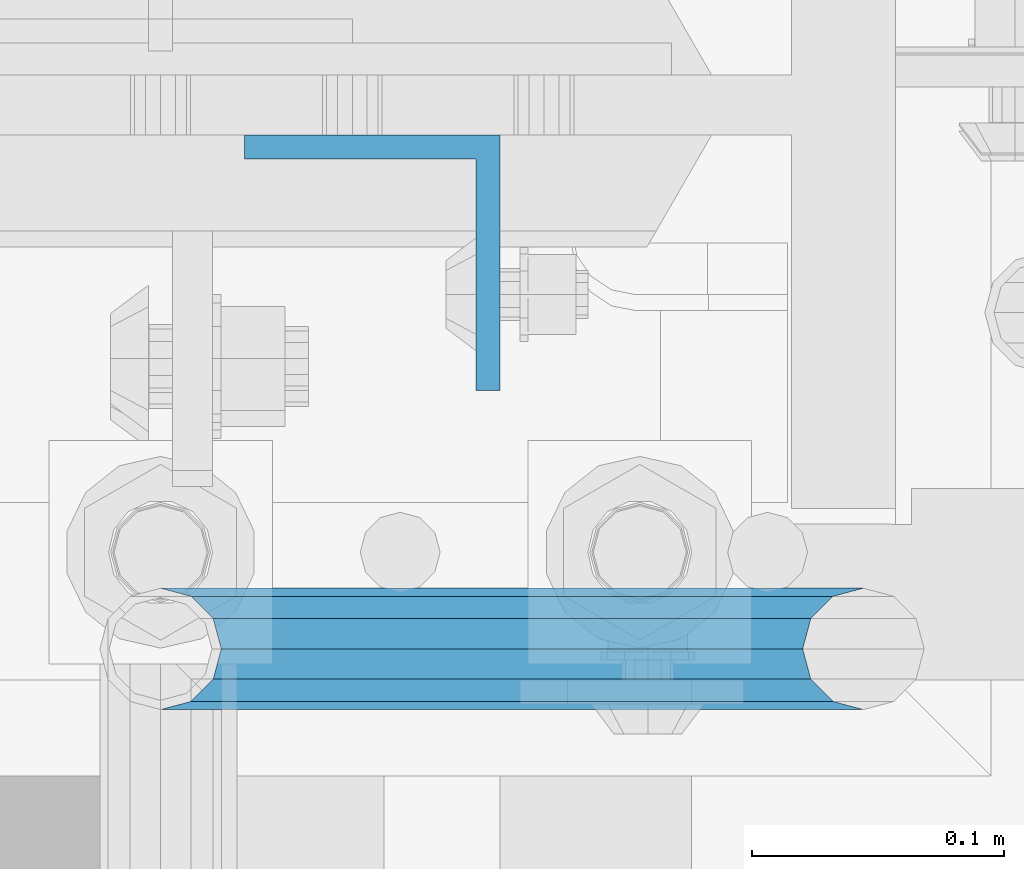
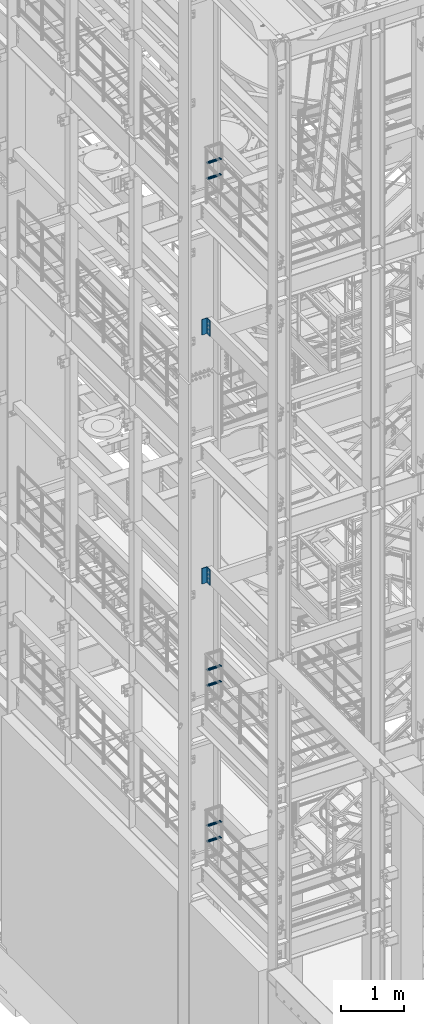
# One storey, part 1159 of 1876: 8 beams, 5 elements without a shape of their own.
"""IFC2X3 building model written with IfcOpenShell, lengths in millimetres."""

from ifc_helpers import new_model, si_unit, frame, origin_with_axes, place, context, subcontext, project, spatial, faceted_brep, material, type_object, element, aggregate, save


model = new_model("IFC2X3")

# Units and contexts
model_context = context("Model", 3, precision=1e-05, world=origin_with_axes())
body_context = subcontext(model_context, "Body", "Model", "MODEL_VIEW")
ifc_project = project(units=[si_unit("LENGTHUNIT", "METRE", prefix="MILLI"), si_unit("AREAUNIT", "SQUARE_METRE"), si_unit("VOLUMEUNIT", "CUBIC_METRE"), si_unit("MASSUNIT", "GRAM", prefix="KILO"), si_unit("TIMEUNIT", "SECOND"), si_unit("PLANEANGLEUNIT", "RADIAN"), si_unit("SOLIDANGLEUNIT", "STERADIAN"), si_unit("THERMODYNAMICTEMPERATUREUNIT", "DEGREE_CELSIUS"), si_unit("LUMINOUSINTENSITYUNIT", "LUMEN")], contexts=[model_context])

# Site, building, storey
site_placement = place(None, origin_with_axes())
site = spatial("IfcSite", under=ifc_project, at=site_placement, CompositionType="ELEMENT")
building_placement = place(site_placement, origin_with_axes())
building = spatial("IfcBuilding", under=site, at=building_placement, Name="Undefined", CompositionType="ELEMENT")
storey_placement = place(building_placement, origin_with_axes())
storey = spatial("IfcBuildingStorey", under=building, at=storey_placement, Name="Undefined", CompositionType="ELEMENT", Elevation=0.0)

# Assembly, beams
assembly_1_placement = place(storey_placement, origin_with_axes())
assembly_1 = element("IfcElementAssembly", 1, at=assembly_1_placement, inside=storey, Name="RAIL", AssemblyPlace="NOTDEFINED", PredefinedType="RIGID_FRAME")
ifc_material_1 = material()
beam_type_1 = type_object("IfcBeamType", Name="PIPE1-1/2SCH40", PredefinedType="NOTDEFINED")
beam_1_placement = place(assembly_1_placement, frame((0.0, -4788.2175, 18449.925000036), z_axis=(0.0, 0.0, 1.0), x_axis=(1.0, 0.0, 0.0)))
beam_1 = element("IfcBeam", 2, at=beam_1_placement, type_object=beam_type_1, material=ifc_material_1, Name="RAIL", ObjectType="PIPE1-1/2SCH40", context=body_context, shape_type="Brep", body=[
    faceted_brep([(258.502800903171, -12.0650000000005, 20.8971929933177), (258.502800903171, -12.0650000000005, 15.8661214311796), (258.009372465309, -10.2235000000001, 17.7076214311819), (255.26999389649, 0.0, 20.4470000000001), (255.26999389649, 0.0, 24.130000000001), (258.009372465309, 10.2235000000001, 17.7076214311819), (258.502800903171, 12.0650000000005, 15.8661214311796), (258.502800903171, 12.0650000000005, 20.8971929933177), (279.399993896489, 24.1299999999992, 0.0), (267.33499389649, 20.8971929933177, 12.0649999999987), (267.33499389649, 20.8971929933177, -12.0649999999987), (264.145422334351, 17.7076214311801, 10.2235000000001), (266.884800903171, 20.4470000000001, 0.0), (264.145422334351, 17.7076214311801, -10.2235000000001), (258.502800903171, 12.0650000000005, -15.8661214311796), (258.502800903171, 12.0650000000005, -20.8971929933177), (258.009372465309, 10.2235000000001, -17.7076214311819), (255.26999389649, 0.0, -20.4470000000001), (255.26999389649, 0.0, -24.130000000001), (258.502800903171, -12.0650000000005, -15.8661214311796), (258.502800903171, -12.0650000000005, -20.8971929933177), (258.009372465309, -10.2235000000001, -17.7076214311819), (279.399993896489, -24.1299999999992, 0.0), (267.33499389649, -20.8971929933177, -12.0649999999987), (267.33499389649, -20.8971929933177, 12.0649999999987), (264.145422334351, -17.7076214311801, -10.2235000000001), (266.884800903171, -20.4470000000001, 0.0), (264.145422334351, -17.7076214311801, 10.2235000000001), (12.0650000000064, -20.8971929933177, -12.0649999999987), (20.8971929933249, -12.0650000000005, -20.8971929933177), (0.0, 24.1299999999992, 0.0), (12.0650000000064, 20.8971929933177, -12.0649999999987), (12.0650000000064, 20.8971929933177, 12.0649999999987), (20.8971929933249, 12.0650000000005, 20.8971929933177), (24.1300000000064, 0.0, 24.130000000001), (20.8971929933249, 12.0650000000005, -20.8971929933177), (24.1300000000063, 0.0, -24.130000000001), (24.1300000000063, 0.0, -20.4470000000001), (20.8971929933249, -12.0650000000005, -15.8661214311796), (21.3906214311868, -10.2235000000001, -17.7076214311819), (21.3906214311868, 10.2235000000001, -17.7076214311819), (20.8971929933249, 12.0650000000005, -15.8661214311796), (15.2545715621445, 17.7076214311801, -10.2235000000001), (12.5151929933249, 20.4470000000001, 0.0), (15.2545715621445, 17.7076214311801, 10.2235000000001), (20.8971929933249, 12.0650000000005, 15.8661214311796), (21.3906214311868, 10.2235000000001, 17.7076214311819), (24.1300000000064, 0.0, 20.4470000000001), (21.3906214311868, -10.2235000000001, 17.7076214311819), (20.8971929933249, -12.0650000000005, 15.8661214311796), (20.8971929933249, -12.0650000000005, 20.8971929933177), (12.0650000000064, -20.8971929933177, 12.0649999999987), (0.0, -24.1299999999992, 0.0), (15.2545715621445, -17.7076214311801, 10.2235000000001), (12.5151929933249, -20.4470000000001, 0.0), (15.2545715621445, -17.7076214311801, -10.2235000000001)], [[[0, 1, 2, 3, 4]], [[4, 3, 5, 6, 7]], [[8, 9, 10]], [[7, 6, 11, 12, 13, 14, 15, 10, 9]], [[16, 17, 18, 15, 14]], [[19, 20, 18, 17, 21]], [[22, 23, 24]], [[24, 23, 20, 19, 25, 26, 27, 1, 0]], [[28, 29, 20, 23]], [[30, 31, 32]], [[33, 34, 4, 7]], [[32, 33, 7, 9]], [[30, 32, 9, 8]], [[31, 30, 8, 10]], [[35, 31, 10, 15]], [[36, 35, 15, 18]], [[29, 36, 18, 20]], [[37, 36, 29, 38, 39]], [[40, 41, 35, 36, 37]], [[32, 31, 35, 41, 42, 43, 44, 45, 33]], [[33, 45, 46, 47, 34]], [[34, 47, 48, 49, 50]], [[34, 50, 0, 4]], [[50, 51, 24, 0]], [[51, 52, 22, 24]], [[52, 28, 23, 22]], [[51, 28, 52]], [[50, 49, 53, 54, 55, 38, 29, 28, 51]], [[55, 54, 26, 25]], [[21, 39, 38, 55, 25, 19]], [[37, 39, 21, 17]], [[40, 37, 17, 16]], [[42, 41, 40, 16, 14, 13]], [[43, 42, 13, 12]], [[44, 43, 12, 11]], [[5, 46, 45, 44, 11, 6]], [[47, 46, 5, 3]], [[48, 47, 3, 2]], [[53, 49, 48, 2, 1, 27]], [[54, 53, 27, 26]]]),
])
beam_2_placement = place(assembly_1_placement, frame((0.0, -4788.2175, 18754.7250000359), z_axis=(0.0, 0.0, 1.0), x_axis=(1.0, 0.0, 0.0)))
beam_2 = element("IfcBeam", 3, at=beam_2_placement, type_object=beam_type_1, material=ifc_material_1, Name="RAIL", ObjectType="PIPE1-1/2SCH40", context=body_context, shape_type="Brep", body=[
    faceted_brep([(258.502800903171, -12.0650000000005, 20.8971929933177), (258.502800903171, -12.0650000000005, 15.8661214311796), (258.009372465309, -10.2235000000001, 17.7076214311819), (255.26999389649, 0.0, 20.4470000000001), (255.26999389649, 0.0, 24.130000000001), (258.009372465309, 10.2235000000001, 17.7076214311819), (258.502800903171, 12.0650000000005, 15.8661214311796), (258.502800903171, 12.0650000000005, 20.8971929933177), (279.399993896489, 24.1299999999992, 0.0), (267.33499389649, 20.8971929933177, 12.0649999999987), (267.33499389649, 20.8971929933177, -12.0649999999987), (264.145422334351, 17.7076214311801, 10.2235000000001), (266.884800903171, 20.4470000000001, 0.0), (264.145422334351, 17.7076214311801, -10.2235000000001), (258.502800903171, 12.0650000000005, -15.8661214311796), (258.502800903171, 12.0650000000005, -20.8971929933177), (258.009372465309, 10.2235000000001, -17.7076214311819), (255.26999389649, 0.0, -20.4470000000001), (255.26999389649, 0.0, -24.130000000001), (258.502800903171, -12.0650000000005, -15.8661214311796), (258.502800903171, -12.0650000000005, -20.8971929933177), (258.009372465309, -10.2235000000001, -17.7076214311819), (279.399993896489, -24.1299999999992, 0.0), (267.33499389649, -20.8971929933177, -12.0649999999987), (267.33499389649, -20.8971929933177, 12.0649999999987), (264.145422334351, -17.7076214311801, -10.2235000000001), (266.884800903171, -20.4470000000001, 0.0), (264.145422334351, -17.7076214311801, 10.2235000000001), (12.0650000000064, -20.8971929933177, -12.0649999999987), (20.8971929933249, -12.0650000000005, -20.8971929933177), (0.0, 24.1299999999992, 0.0), (12.0650000000064, 20.8971929933177, -12.0649999999987), (12.0650000000064, 20.8971929933177, 12.0649999999987), (20.8971929933249, 12.0650000000005, 20.8971929933177), (24.1300000000064, 0.0, 24.130000000001), (20.8971929933249, 12.0650000000005, -20.8971929933177), (24.1300000000063, 0.0, -24.130000000001), (24.1300000000063, 0.0, -20.4470000000001), (20.8971929933249, -12.0650000000005, -15.8661214311796), (21.3906214311868, -10.2235000000001, -17.7076214311819), (21.3906214311868, 10.2235000000001, -17.7076214311819), (20.8971929933249, 12.0650000000005, -15.8661214311796), (15.2545715621445, 17.7076214311801, -10.2235000000001), (12.5151929933249, 20.4470000000001, 0.0), (15.2545715621445, 17.7076214311801, 10.2235000000001), (20.8971929933249, 12.0650000000005, 15.8661214311796), (21.3906214311868, 10.2235000000001, 17.7076214311819), (24.1300000000064, 0.0, 20.4470000000001), (21.3906214311868, -10.2235000000001, 17.7076214311819), (20.8971929933249, -12.0650000000005, 15.8661214311796), (20.8971929933249, -12.0650000000005, 20.8971929933177), (12.0650000000064, -20.8971929933177, 12.0649999999987), (0.0, -24.1299999999992, 0.0), (15.2545715621445, -17.7076214311801, 10.2235000000001), (12.5151929933249, -20.4470000000001, 0.0), (15.2545715621445, -17.7076214311801, -10.2235000000001)], [[[0, 1, 2, 3, 4]], [[4, 3, 5, 6, 7]], [[8, 9, 10]], [[7, 6, 11, 12, 13, 14, 15, 10, 9]], [[16, 17, 18, 15, 14]], [[19, 20, 18, 17, 21]], [[22, 23, 24]], [[24, 23, 20, 19, 25, 26, 27, 1, 0]], [[28, 29, 20, 23]], [[30, 31, 32]], [[33, 34, 4, 7]], [[32, 33, 7, 9]], [[30, 32, 9, 8]], [[31, 30, 8, 10]], [[35, 31, 10, 15]], [[36, 35, 15, 18]], [[29, 36, 18, 20]], [[37, 36, 29, 38, 39]], [[40, 41, 35, 36, 37]], [[32, 31, 35, 41, 42, 43, 44, 45, 33]], [[33, 45, 46, 47, 34]], [[34, 47, 48, 49, 50]], [[34, 50, 0, 4]], [[50, 51, 24, 0]], [[51, 52, 22, 24]], [[52, 28, 23, 22]], [[51, 28, 52]], [[50, 49, 53, 54, 55, 38, 29, 28, 51]], [[55, 54, 26, 25]], [[21, 39, 38, 55, 25, 19]], [[37, 39, 21, 17]], [[40, 37, 17, 16]], [[42, 41, 40, 16, 14, 13]], [[43, 42, 13, 12]], [[44, 43, 12, 11]], [[5, 46, 45, 44, 11, 6]], [[47, 46, 5, 3]], [[48, 47, 3, 2]], [[53, 49, 48, 2, 1, 27]], [[54, 53, 27, 26]]]),
])
aggregate(assembly_1, [beam_1, beam_2])

assembly_2_placement = place(storey_placement, origin_with_axes())
assembly_2 = element("IfcElementAssembly", 4, at=assembly_2_placement, inside=storey, Name="RAIL", AssemblyPlace="NOTDEFINED", PredefinedType="RIGID_FRAME")
beam_3_placement = place(assembly_2_placement, frame((0.0, -4788.2175, 8620.125000036), z_axis=(0.0, 0.0, 1.0), x_axis=(1.0, 0.0, 0.0)))
beam_3 = element("IfcBeam", 5, at=beam_3_placement, type_object=beam_type_1, material=ifc_material_1, Name="RAIL", ObjectType="PIPE1-1/2SCH40", context=body_context, shape_type="Brep", body=[
    faceted_brep([(258.502800903171, -12.0650000000005, 20.8971929933177), (258.502800903171, -12.0650000000005, 15.8661214311796), (258.009372465309, -10.2235000000001, 17.7076214311819), (255.26999389649, 0.0, 20.4470000000001), (255.26999389649, 0.0, 24.130000000001), (258.009372465309, 10.2235000000001, 17.7076214311819), (258.502800903171, 12.0650000000005, 15.8661214311796), (258.502800903171, 12.0650000000005, 20.8971929933177), (279.399993896489, 24.1299999999992, 0.0), (267.33499389649, 20.8971929933177, 12.0649999999987), (267.33499389649, 20.8971929933177, -12.0649999999987), (264.145422334351, 17.7076214311801, 10.2235000000001), (266.884800903171, 20.4470000000001, 0.0), (264.145422334351, 17.7076214311801, -10.2235000000001), (258.502800903171, 12.0650000000005, -15.8661214311796), (258.502800903171, 12.0650000000005, -20.8971929933177), (258.009372465309, 10.2235000000001, -17.7076214311819), (255.26999389649, 0.0, -20.4470000000001), (255.26999389649, 0.0, -24.130000000001), (258.502800903171, -12.0650000000005, -15.8661214311796), (258.502800903171, -12.0650000000005, -20.8971929933177), (258.009372465309, -10.2235000000001, -17.7076214311819), (279.399993896489, -24.1299999999992, 0.0), (267.33499389649, -20.8971929933177, -12.0649999999987), (267.33499389649, -20.8971929933177, 12.0649999999987), (264.145422334351, -17.7076214311801, -10.2235000000001), (266.884800903171, -20.4470000000001, 0.0), (264.145422334351, -17.7076214311801, 10.2235000000001), (12.0650000000064, -20.8971929933177, -12.0649999999987), (20.8971929933249, -12.0650000000005, -20.8971929933177), (0.0, 24.1299999999992, 0.0), (12.0650000000064, 20.8971929933177, -12.0649999999987), (12.0650000000064, 20.8971929933177, 12.0649999999987), (20.8971929933249, 12.0650000000005, 20.8971929933177), (24.1300000000064, 0.0, 24.130000000001), (20.8971929933249, 12.0650000000005, -20.8971929933177), (24.1300000000063, 0.0, -24.130000000001), (24.1300000000063, 0.0, -20.4470000000001), (20.8971929933249, -12.0650000000005, -15.8661214311796), (21.3906214311868, -10.2235000000001, -17.7076214311819), (21.3906214311868, 10.2235000000001, -17.7076214311819), (20.8971929933249, 12.0650000000005, -15.8661214311796), (15.2545715621445, 17.7076214311801, -10.2235000000001), (12.5151929933249, 20.4470000000001, 0.0), (15.2545715621445, 17.7076214311801, 10.2235000000001), (20.8971929933249, 12.0650000000005, 15.8661214311796), (21.3906214311868, 10.2235000000001, 17.7076214311819), (24.1300000000064, 0.0, 20.4470000000001), (21.3906214311868, -10.2235000000001, 17.7076214311819), (20.8971929933249, -12.0650000000005, 15.8661214311796), (20.8971929933249, -12.0650000000005, 20.8971929933177), (12.0650000000064, -20.8971929933177, 12.0649999999987), (0.0, -24.1299999999992, 0.0), (15.2545715621445, -17.7076214311801, 10.2235000000001), (12.5151929933249, -20.4470000000001, 0.0), (15.2545715621445, -17.7076214311801, -10.2235000000001)], [[[0, 1, 2, 3, 4]], [[4, 3, 5, 6, 7]], [[8, 9, 10]], [[7, 6, 11, 12, 13, 14, 15, 10, 9]], [[16, 17, 18, 15, 14]], [[19, 20, 18, 17, 21]], [[22, 23, 24]], [[24, 23, 20, 19, 25, 26, 27, 1, 0]], [[28, 29, 20, 23]], [[30, 31, 32]], [[33, 34, 4, 7]], [[32, 33, 7, 9]], [[30, 32, 9, 8]], [[31, 30, 8, 10]], [[35, 31, 10, 15]], [[36, 35, 15, 18]], [[29, 36, 18, 20]], [[37, 36, 29, 38, 39]], [[40, 41, 35, 36, 37]], [[32, 31, 35, 41, 42, 43, 44, 45, 33]], [[33, 45, 46, 47, 34]], [[34, 47, 48, 49, 50]], [[34, 50, 0, 4]], [[50, 51, 24, 0]], [[51, 52, 22, 24]], [[52, 28, 23, 22]], [[51, 28, 52]], [[50, 49, 53, 54, 55, 38, 29, 28, 51]], [[55, 54, 26, 25]], [[21, 39, 38, 55, 25, 19]], [[37, 39, 21, 17]], [[40, 37, 17, 16]], [[42, 41, 40, 16, 14, 13]], [[43, 42, 13, 12]], [[44, 43, 12, 11]], [[5, 46, 45, 44, 11, 6]], [[47, 46, 5, 3]], [[48, 47, 3, 2]], [[53, 49, 48, 2, 1, 27]], [[54, 53, 27, 26]]]),
])
beam_4_placement = place(assembly_2_placement, frame((0.0, -4788.2175, 8924.92500003594), z_axis=(0.0, 0.0, 1.0), x_axis=(1.0, 0.0, 0.0)))
beam_4 = element("IfcBeam", 6, at=beam_4_placement, type_object=beam_type_1, material=ifc_material_1, Name="RAIL", ObjectType="PIPE1-1/2SCH40", context=body_context, shape_type="Brep", body=[
    faceted_brep([(258.502800903171, -12.0650000000005, 20.8971929933177), (258.502800903171, -12.0650000000005, 15.8661214311796), (258.009372465309, -10.2235000000001, 17.7076214311819), (255.26999389649, 0.0, 20.4470000000001), (255.26999389649, 0.0, 24.130000000001), (258.009372465309, 10.2235000000001, 17.7076214311819), (258.502800903171, 12.0650000000005, 15.8661214311796), (258.502800903171, 12.0650000000005, 20.8971929933177), (279.399993896489, 24.1299999999992, 0.0), (267.33499389649, 20.8971929933177, 12.0649999999987), (267.33499389649, 20.8971929933177, -12.0649999999987), (264.145422334351, 17.7076214311801, 10.2235000000001), (266.884800903171, 20.4470000000001, 0.0), (264.145422334351, 17.7076214311801, -10.2235000000001), (258.502800903171, 12.0650000000005, -15.8661214311796), (258.502800903171, 12.0650000000005, -20.8971929933177), (258.009372465309, 10.2235000000001, -17.7076214311819), (255.26999389649, 0.0, -20.4470000000001), (255.26999389649, 0.0, -24.130000000001), (258.502800903171, -12.0650000000005, -15.8661214311796), (258.502800903171, -12.0650000000005, -20.8971929933177), (258.009372465309, -10.2235000000001, -17.7076214311819), (279.399993896489, -24.1299999999992, 0.0), (267.33499389649, -20.8971929933177, -12.0649999999987), (267.33499389649, -20.8971929933177, 12.0649999999987), (264.145422334351, -17.7076214311801, -10.2235000000001), (266.884800903171, -20.4470000000001, 0.0), (264.145422334351, -17.7076214311801, 10.2235000000001), (12.0650000000064, -20.8971929933177, -12.0649999999987), (20.8971929933249, -12.0650000000005, -20.8971929933177), (0.0, 24.1299999999992, 0.0), (12.0650000000064, 20.8971929933177, -12.0649999999987), (12.0650000000064, 20.8971929933177, 12.0649999999987), (20.8971929933249, 12.0650000000005, 20.8971929933177), (24.1300000000064, 0.0, 24.130000000001), (20.8971929933249, 12.0650000000005, -20.8971929933177), (24.1300000000063, 0.0, -24.130000000001), (24.1300000000063, 0.0, -20.4470000000001), (20.8971929933249, -12.0650000000005, -15.8661214311796), (21.3906214311868, -10.2235000000001, -17.7076214311819), (21.3906214311868, 10.2235000000001, -17.7076214311819), (20.8971929933249, 12.0650000000005, -15.8661214311796), (15.2545715621445, 17.7076214311801, -10.2235000000001), (12.5151929933249, 20.4470000000001, 0.0), (15.2545715621445, 17.7076214311801, 10.2235000000001), (20.8971929933249, 12.0650000000005, 15.8661214311796), (21.3906214311868, 10.2235000000001, 17.7076214311819), (24.1300000000064, 0.0, 20.4470000000001), (21.3906214311868, -10.2235000000001, 17.7076214311819), (20.8971929933249, -12.0650000000005, 15.8661214311796), (20.8971929933249, -12.0650000000005, 20.8971929933177), (12.0650000000064, -20.8971929933177, 12.0649999999987), (0.0, -24.1299999999992, 0.0), (15.2545715621445, -17.7076214311801, 10.2235000000001), (12.5151929933249, -20.4470000000001, 0.0), (15.2545715621445, -17.7076214311801, -10.2235000000001)], [[[0, 1, 2, 3, 4]], [[4, 3, 5, 6, 7]], [[8, 9, 10]], [[7, 6, 11, 12, 13, 14, 15, 10, 9]], [[16, 17, 18, 15, 14]], [[19, 20, 18, 17, 21]], [[22, 23, 24]], [[24, 23, 20, 19, 25, 26, 27, 1, 0]], [[28, 29, 20, 23]], [[30, 31, 32]], [[33, 34, 4, 7]], [[32, 33, 7, 9]], [[30, 32, 9, 8]], [[31, 30, 8, 10]], [[35, 31, 10, 15]], [[36, 35, 15, 18]], [[29, 36, 18, 20]], [[37, 36, 29, 38, 39]], [[40, 41, 35, 36, 37]], [[32, 31, 35, 41, 42, 43, 44, 45, 33]], [[33, 45, 46, 47, 34]], [[34, 47, 48, 49, 50]], [[34, 50, 0, 4]], [[50, 51, 24, 0]], [[51, 52, 22, 24]], [[52, 28, 23, 22]], [[51, 28, 52]], [[50, 49, 53, 54, 55, 38, 29, 28, 51]], [[55, 54, 26, 25]], [[21, 39, 38, 55, 25, 19]], [[37, 39, 21, 17]], [[40, 37, 17, 16]], [[42, 41, 40, 16, 14, 13]], [[43, 42, 13, 12]], [[44, 43, 12, 11]], [[5, 46, 45, 44, 11, 6]], [[47, 46, 5, 3]], [[48, 47, 3, 2]], [[53, 49, 48, 2, 1, 27]], [[54, 53, 27, 26]]]),
])
aggregate(assembly_2, [beam_3, beam_4])

assembly_3_placement = place(storey_placement, origin_with_axes())
assembly_3 = element("IfcElementAssembly", 7, at=assembly_3_placement, inside=storey, Name="RAIL", AssemblyPlace="NOTDEFINED", PredefinedType="RIGID_FRAME")
beam_5_placement = place(assembly_3_placement, frame((0.0, -4788.2175, 5597.525000036), z_axis=(0.0, 0.0, 1.0), x_axis=(1.0, 0.0, 0.0)))
beam_5 = element("IfcBeam", 8, at=beam_5_placement, type_object=beam_type_1, material=ifc_material_1, Name="RAIL", ObjectType="PIPE1-1/2SCH40", context=body_context, shape_type="Brep", body=[
    faceted_brep([(258.502800903171, -12.0650000000005, 20.8971929933177), (258.502800903171, -12.0650000000005, 15.8661214311796), (258.009372465309, -10.2235000000001, 17.7076214311819), (255.26999389649, 0.0, 20.4470000000001), (255.26999389649, 0.0, 24.130000000001), (258.009372465309, 10.2235000000001, 17.7076214311819), (258.502800903171, 12.0650000000005, 15.8661214311796), (258.502800903171, 12.0650000000005, 20.8971929933177), (279.399993896489, 24.1299999999992, 0.0), (267.33499389649, 20.8971929933177, 12.0649999999987), (267.33499389649, 20.8971929933177, -12.0649999999987), (264.145422334351, 17.7076214311801, 10.2235000000001), (266.884800903171, 20.4470000000001, 0.0), (264.145422334351, 17.7076214311801, -10.2235000000001), (258.502800903171, 12.0650000000005, -15.8661214311796), (258.502800903171, 12.0650000000005, -20.8971929933177), (258.009372465309, 10.2235000000001, -17.7076214311819), (255.26999389649, 0.0, -20.4470000000001), (255.26999389649, 0.0, -24.130000000001), (258.502800903171, -12.0650000000005, -15.8661214311796), (258.502800903171, -12.0650000000005, -20.8971929933177), (258.009372465309, -10.2235000000001, -17.7076214311819), (279.399993896489, -24.1299999999992, 0.0), (267.33499389649, -20.8971929933177, -12.0649999999987), (267.33499389649, -20.8971929933177, 12.0649999999987), (264.145422334351, -17.7076214311801, -10.2235000000001), (266.884800903171, -20.4470000000001, 0.0), (264.145422334351, -17.7076214311801, 10.2235000000001), (12.0650000000064, -20.8971929933177, -12.0649999999987), (20.8971929933249, -12.0650000000005, -20.8971929933177), (0.0, 24.1299999999992, 0.0), (12.0650000000064, 20.8971929933177, -12.0649999999987), (12.0650000000064, 20.8971929933177, 12.0649999999987), (20.8971929933249, 12.0650000000005, 20.8971929933177), (24.1300000000064, 0.0, 24.130000000001), (20.8971929933249, 12.0650000000005, -20.8971929933177), (24.1300000000063, 0.0, -24.130000000001), (24.1300000000063, 0.0, -20.4470000000001), (20.8971929933249, -12.0650000000005, -15.8661214311796), (21.3906214311868, -10.2235000000001, -17.7076214311819), (21.3906214311868, 10.2235000000001, -17.7076214311819), (20.8971929933249, 12.0650000000005, -15.8661214311796), (15.2545715621445, 17.7076214311801, -10.2235000000001), (12.5151929933249, 20.4470000000001, 0.0), (15.2545715621445, 17.7076214311801, 10.2235000000001), (20.8971929933249, 12.0650000000005, 15.8661214311796), (21.3906214311868, 10.2235000000001, 17.7076214311819), (24.1300000000064, 0.0, 20.4470000000001), (21.3906214311868, -10.2235000000001, 17.7076214311819), (20.8971929933249, -12.0650000000005, 15.8661214311796), (20.8971929933249, -12.0650000000005, 20.8971929933177), (12.0650000000064, -20.8971929933177, 12.0649999999987), (0.0, -24.1299999999992, 0.0), (15.2545715621445, -17.7076214311801, 10.2235000000001), (12.5151929933249, -20.4470000000001, 0.0), (15.2545715621445, -17.7076214311801, -10.2235000000001)], [[[0, 1, 2, 3, 4]], [[4, 3, 5, 6, 7]], [[8, 9, 10]], [[7, 6, 11, 12, 13, 14, 15, 10, 9]], [[16, 17, 18, 15, 14]], [[19, 20, 18, 17, 21]], [[22, 23, 24]], [[24, 23, 20, 19, 25, 26, 27, 1, 0]], [[28, 29, 20, 23]], [[30, 31, 32]], [[33, 34, 4, 7]], [[32, 33, 7, 9]], [[30, 32, 9, 8]], [[31, 30, 8, 10]], [[35, 31, 10, 15]], [[36, 35, 15, 18]], [[29, 36, 18, 20]], [[37, 36, 29, 38, 39]], [[40, 41, 35, 36, 37]], [[32, 31, 35, 41, 42, 43, 44, 45, 33]], [[33, 45, 46, 47, 34]], [[34, 47, 48, 49, 50]], [[34, 50, 0, 4]], [[50, 51, 24, 0]], [[51, 52, 22, 24]], [[52, 28, 23, 22]], [[51, 28, 52]], [[50, 49, 53, 54, 55, 38, 29, 28, 51]], [[55, 54, 26, 25]], [[21, 39, 38, 55, 25, 19]], [[37, 39, 21, 17]], [[40, 37, 17, 16]], [[42, 41, 40, 16, 14, 13]], [[43, 42, 13, 12]], [[44, 43, 12, 11]], [[5, 46, 45, 44, 11, 6]], [[47, 46, 5, 3]], [[48, 47, 3, 2]], [[53, 49, 48, 2, 1, 27]], [[54, 53, 27, 26]]]),
])
beam_6_placement = place(assembly_3_placement, frame((0.0, -4788.2175, 5902.32500003594), z_axis=(0.0, 0.0, 1.0), x_axis=(1.0, 0.0, 0.0)))
beam_6 = element("IfcBeam", 9, at=beam_6_placement, type_object=beam_type_1, material=ifc_material_1, Name="RAIL", ObjectType="PIPE1-1/2SCH40", context=body_context, shape_type="Brep", body=[
    faceted_brep([(258.502800903171, -12.0650000000005, 20.8971929933177), (258.502800903171, -12.0650000000005, 15.8661214311796), (258.009372465309, -10.2235000000001, 17.7076214311819), (255.26999389649, 0.0, 20.4470000000001), (255.26999389649, 0.0, 24.130000000001), (258.009372465309, 10.2235000000001, 17.7076214311819), (258.502800903171, 12.0650000000005, 15.8661214311796), (258.502800903171, 12.0650000000005, 20.8971929933177), (279.399993896489, 24.1299999999992, 0.0), (267.33499389649, 20.8971929933177, 12.0649999999987), (267.33499389649, 20.8971929933177, -12.0649999999987), (264.145422334351, 17.7076214311801, 10.2235000000001), (266.884800903171, 20.4470000000001, 0.0), (264.145422334351, 17.7076214311801, -10.2235000000001), (258.502800903171, 12.0650000000005, -15.8661214311796), (258.502800903171, 12.0650000000005, -20.8971929933177), (258.009372465309, 10.2235000000001, -17.7076214311819), (255.26999389649, 0.0, -20.4470000000001), (255.26999389649, 0.0, -24.130000000001), (258.502800903171, -12.0650000000005, -15.8661214311796), (258.502800903171, -12.0650000000005, -20.8971929933177), (258.009372465309, -10.2235000000001, -17.7076214311819), (279.399993896489, -24.1299999999992, 0.0), (267.33499389649, -20.8971929933177, -12.0649999999987), (267.33499389649, -20.8971929933177, 12.0649999999987), (264.145422334351, -17.7076214311801, -10.2235000000001), (266.884800903171, -20.4470000000001, 0.0), (264.145422334351, -17.7076214311801, 10.2235000000001), (12.0650000000064, -20.8971929933177, -12.0649999999987), (20.8971929933249, -12.0650000000005, -20.8971929933177), (0.0, 24.1299999999992, 0.0), (12.0650000000064, 20.8971929933177, -12.0649999999987), (12.0650000000064, 20.8971929933177, 12.0649999999987), (20.8971929933249, 12.0650000000005, 20.8971929933177), (24.1300000000064, 0.0, 24.130000000001), (20.8971929933249, 12.0650000000005, -20.8971929933177), (24.1300000000063, 0.0, -24.130000000001), (24.1300000000063, 0.0, -20.4470000000001), (20.8971929933249, -12.0650000000005, -15.8661214311796), (21.3906214311868, -10.2235000000001, -17.7076214311819), (21.3906214311868, 10.2235000000001, -17.7076214311819), (20.8971929933249, 12.0650000000005, -15.8661214311796), (15.2545715621445, 17.7076214311801, -10.2235000000001), (12.5151929933249, 20.4470000000001, 0.0), (15.2545715621445, 17.7076214311801, 10.2235000000001), (20.8971929933249, 12.0650000000005, 15.8661214311796), (21.3906214311868, 10.2235000000001, 17.7076214311819), (24.1300000000064, 0.0, 20.4470000000001), (21.3906214311868, -10.2235000000001, 17.7076214311819), (20.8971929933249, -12.0650000000005, 15.8661214311796), (20.8971929933249, -12.0650000000005, 20.8971929933177), (12.0650000000064, -20.8971929933177, 12.0649999999987), (0.0, -24.1299999999992, 0.0), (15.2545715621445, -17.7076214311801, 10.2235000000001), (12.5151929933249, -20.4470000000001, 0.0), (15.2545715621445, -17.7076214311801, -10.2235000000001)], [[[0, 1, 2, 3, 4]], [[4, 3, 5, 6, 7]], [[8, 9, 10]], [[7, 6, 11, 12, 13, 14, 15, 10, 9]], [[16, 17, 18, 15, 14]], [[19, 20, 18, 17, 21]], [[22, 23, 24]], [[24, 23, 20, 19, 25, 26, 27, 1, 0]], [[28, 29, 20, 23]], [[30, 31, 32]], [[33, 34, 4, 7]], [[32, 33, 7, 9]], [[30, 32, 9, 8]], [[31, 30, 8, 10]], [[35, 31, 10, 15]], [[36, 35, 15, 18]], [[29, 36, 18, 20]], [[37, 36, 29, 38, 39]], [[40, 41, 35, 36, 37]], [[32, 31, 35, 41, 42, 43, 44, 45, 33]], [[33, 45, 46, 47, 34]], [[34, 47, 48, 49, 50]], [[34, 50, 0, 4]], [[50, 51, 24, 0]], [[51, 52, 22, 24]], [[52, 28, 23, 22]], [[51, 28, 52]], [[50, 49, 53, 54, 55, 38, 29, 28, 51]], [[55, 54, 26, 25]], [[21, 39, 38, 55, 25, 19]], [[37, 39, 21, 17]], [[40, 37, 17, 16]], [[42, 41, 40, 16, 14, 13]], [[43, 42, 13, 12]], [[44, 43, 12, 11]], [[5, 46, 45, 44, 11, 6]], [[47, 46, 5, 3]], [[48, 47, 3, 2]], [[53, 49, 48, 2, 1, 27]], [[54, 53, 27, 26]]]),
])
aggregate(assembly_3, [beam_5, beam_6])

# Assembly, beam
assembly_4_placement = place(storey_placement, origin_with_axes())
assembly_4 = element("IfcElementAssembly", 10, at=assembly_4_placement, inside=storey, Name="COLUMN", AssemblyPlace="NOTDEFINED", PredefinedType="RIGID_FRAME")
ifc_material_2 = material(Name="STEEL/A36")
beam_type_2 = type_object("IfcBeamType", Name="L4X4X3/8", PredefinedType="NOTDEFINED")
beam_7_placement = place(assembly_4_placement, frame((84.1375003422536, -4634.70625113818, 15594.0124999981), z_axis=(0.0, -1.0, 0.0), x_axis=(0.0, 0.0, -1.0)))
beam_7 = element("IfcBeam", 11, at=beam_7_placement, type_object=beam_type_2, material=ifc_material_2, Name="ANGLE", ObjectType="L4X4X3/8", context=body_context, shape_type="Brep", body=[
    faceted_brep([(0.0, 50.7999999999993, -50.8000000000002), (0.0, 50.7999999999993, 50.8000000000002), (304.799999999999, 50.7999999999993, 50.8000000000002), (304.799999999999, 50.7999999999993, -50.8000000000002), (0.0, 41.2750000000015, 50.8000000000002), (304.799999999999, 41.2750000000015, 50.8000000000002), (0.0, 41.2750000000015, -41.2749999999996), (304.799999999999, 41.2750000000015, -41.2749999999996), (0.0, -50.7999999999993, -41.2749999999996), (304.799999999999, -50.7999999999993, -41.2749999999996), (0.0, -50.7999999999993, -50.8000000000002), (304.799999999999, -50.7999999999993, -50.8000000000002)], [[[0, 1, 2, 3]], [[1, 4, 5, 2]], [[4, 6, 7, 5]], [[6, 8, 9, 7]], [[8, 10, 11, 9]], [[10, 0, 3, 11]], [[5, 7, 9, 11, 3, 2]], [[10, 8, 6, 4, 1, 0]]]),
])
aggregate(assembly_4, [beam_7])

assembly_5_placement = place(storey_placement, origin_with_axes())
assembly_5 = element("IfcElementAssembly", 12, at=assembly_5_placement, inside=storey, Name="COLUMN", AssemblyPlace="NOTDEFINED", PredefinedType="RIGID_FRAME")
beam_8_placement = place(assembly_5_placement, frame((84.1375003422536, -4634.70625113818, 10766.4249999981), z_axis=(0.0, -1.0, 0.0), x_axis=(0.0, 0.0, -1.0)))
beam_8 = element("IfcBeam", 13, at=beam_8_placement, type_object=beam_type_2, material=ifc_material_2, Name="ANGLE", ObjectType="L4X4X3/8", context=body_context, shape_type="Brep", body=[
    faceted_brep([(0.0, 50.7999999999993, -50.8000000000002), (0.0, 50.7999999999993, 50.8000000000002), (304.799999999999, 50.7999999999993, 50.8000000000002), (304.799999999999, 50.7999999999993, -50.8000000000002), (0.0, 41.2750000000015, 50.8000000000002), (304.799999999999, 41.2750000000015, 50.8000000000002), (0.0, 41.2750000000015, -41.2749999999996), (304.799999999999, 41.2750000000015, -41.2749999999996), (0.0, -50.7999999999993, -41.2749999999996), (304.799999999999, -50.7999999999993, -41.2749999999996), (0.0, -50.7999999999993, -50.8000000000002), (304.799999999999, -50.7999999999993, -50.8000000000002)], [[[0, 1, 2, 3]], [[1, 4, 5, 2]], [[4, 6, 7, 5]], [[6, 8, 9, 7]], [[8, 10, 11, 9]], [[10, 0, 3, 11]], [[5, 7, 9, 11, 3, 2]], [[10, 8, 6, 4, 1, 0]]]),
])
aggregate(assembly_5, [beam_8])

save(model, "model.ifc")
